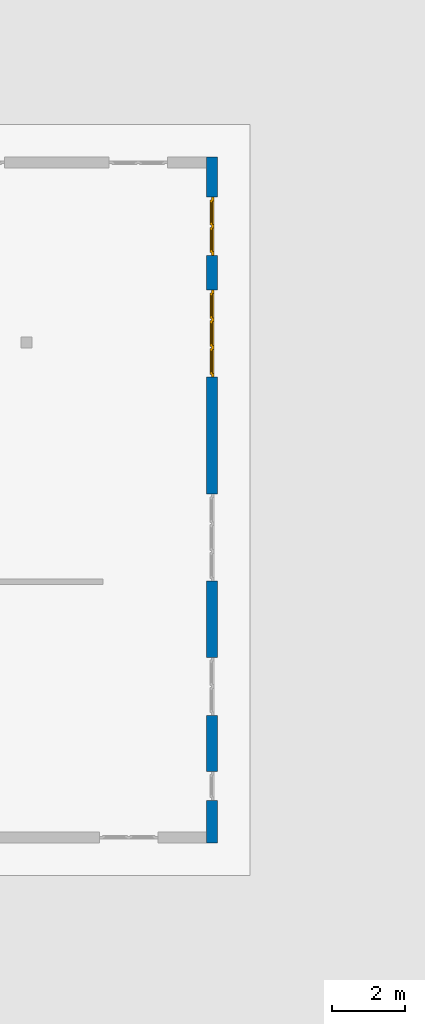
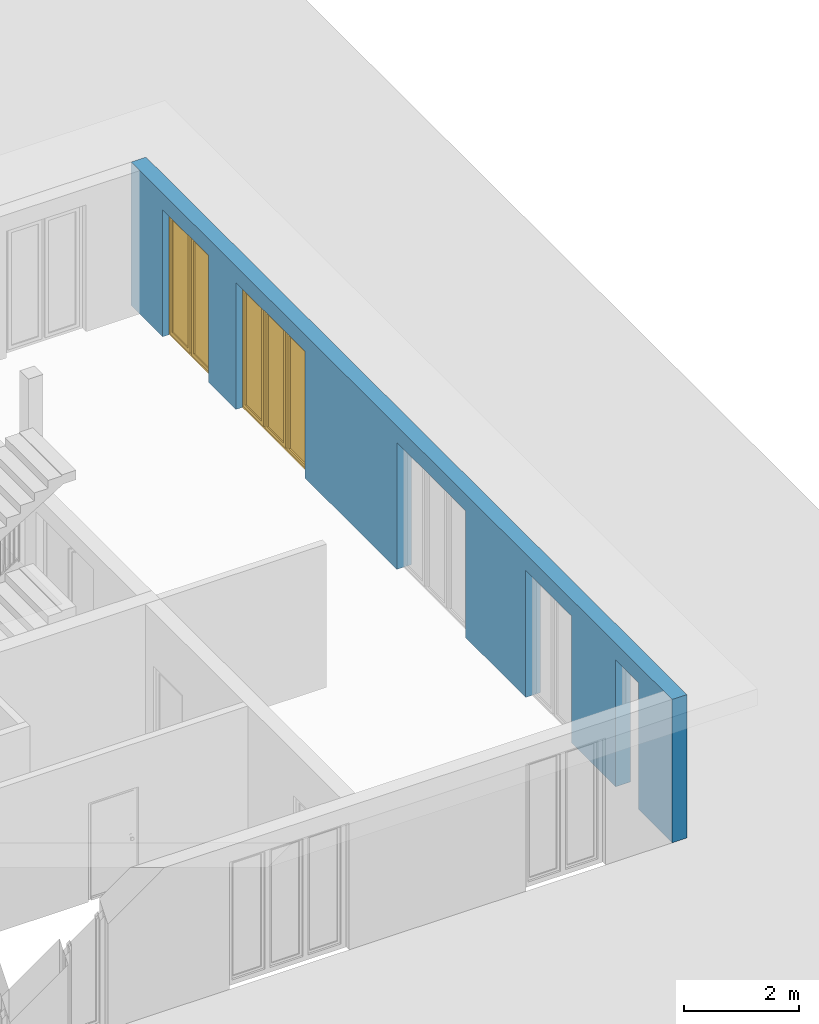
# One storey, part 12 of 23: 2 windows, 1 wall, 5 openings.
"""IFC4 building model written with IfcOpenShell, lengths in metres."""

import ifcopenshell
import ifcopenshell.guid

model = None  # the IFC model being written
_history = None  # IfcOwnerHistory: only IFC2X3 demands one
_inside = {}  # id of a spatial element -> (the spatial element, [elements in it])
_under = {}  # id of a project, library or spatial element -> (it, [spatial elements below it])
_declared = {}  # id of a project -> (the project, [libraries it declares])
_typed = {}  # id of a type object -> (the type object, [elements of that type])
_made_of = {}  # id of a material, layer set ... -> (it, [elements and type objects made of it])


def new_model(schema):
    """Start an empty IFC model of exactly this schema.

    Asked for "IFC4X3", IfcOpenShell would pick the latest addendum, in which some entities
    have other attributes; the version numbers below select the first issue.
    IFC2X3 requires an IfcOwnerHistory on every rooted entity: one is made here for all.
    """
    global model, _history
    if schema == "IFC4X3":
        model = ifcopenshell.file(schema_version=(4, 3, 0, 0))
    else:
        model = ifcopenshell.file(schema=schema)
    _inside.clear()
    _under.clear()
    _declared.clear()
    _typed.clear()
    _made_of.clear()
    _history = None
    if model.schema == "IFC2X3":
        org = make("IfcOrganization", Name="unknown")
        user = make(
            "IfcPersonAndOrganization",
            ThePerson=make("IfcPerson", FamilyName="unknown"),
            TheOrganization=org,
        )
        app = make(
            "IfcApplication",
            ApplicationDeveloper=org,
            Version="unknown",
            ApplicationFullName="unknown",
            ApplicationIdentifier="unknown",
        )
        _history = make(
            "IfcOwnerHistory",
            OwningUser=user,
            OwningApplication=app,
            ChangeAction="ADDED",
            CreationDate=0,
        )
    return model


def make(cls, **values):
    """One entity of the class cls with the attributes given. An attribute that is None is left unset."""
    return model.create_entity(
        cls, **{name: value for name, value in values.items() if value is not None}
    )


def entity(cls, *values):
    """Any entity or typed value of the class cls, its attributes in the order of the schema. None: left unset."""
    e = model.create_entity(cls)
    for i, value in enumerate(values):
        if value is not None:
            e[i] = value
    return e


def rooted(cls, **values):
    """An entity with a GlobalId (a new one), such as an element, a storey or a relation."""
    return make(cls, GlobalId=ifcopenshell.guid.new(), OwnerHistory=_history, **values)


def si_unit(unit_type, name, prefix=None):
    """IfcSIUnit, for example si_unit("LENGTHUNIT", "METRE", prefix="MILLI")."""
    return make("IfcSIUnit", UnitType=unit_type, Prefix=prefix, Name=name)


def converted_unit(unit_type, name, factor, base, dimensions=None, offset=None):
    """IfcConversionBasedUnit, such as the inch: factor (a typed value) times the base unit."""
    return make(
        "IfcConversionBasedUnit"
        if offset is None
        else "IfcConversionBasedUnitWithOffset",
        ConversionOffset=offset,
        Dimensions=None
        if dimensions is None
        else entity("IfcDimensionalExponents", *dimensions),
        UnitType=unit_type,
        Name=name,
        ConversionFactor=make(
            "IfcMeasureWithUnit", ValueComponent=factor, UnitComponent=base
        ),
    )


def derived_unit(unit_type, elements):
    """IfcDerivedUnit: a product of units, each with its exponent."""
    return make(
        "IfcDerivedUnit",
        Elements=[
            make("IfcDerivedUnitElement", Unit=unit, Exponent=power)
            for unit, power in elements
        ],
        UnitType=unit_type,
    )


def assignment(units):
    """IfcUnitAssignment: the units of a project."""
    return None if units is None else make("IfcUnitAssignment", Units=units)


def point(xyz):
    """IfcCartesianPoint."""
    return None if xyz is None else make("IfcCartesianPoint", Coordinates=xyz)


def direction(xyz):
    """IfcDirection."""
    return None if xyz is None else make("IfcDirection", DirectionRatios=xyz)


def frame(location, z_axis=None, x_axis=None):
    """IfcAxis2Placement3D, a coordinate frame: its origin and axes. An axis left out is left unset."""
    return make(
        "IfcAxis2Placement3D",
        Location=point(location),
        Axis=direction(z_axis),
        RefDirection=direction(x_axis),
    )


def origin_with_axes():
    """The frame at (0, 0, 0) with the z axis (0, 0, 1) and the x axis (1, 0, 0) written out."""
    return frame((0.0, 0.0, 0.0), z_axis=(0.0, 0.0, 1.0), x_axis=(1.0, 0.0, 0.0))


def place(relative_to, where):
    """IfcLocalPlacement: puts the frame where relative to a parent placement (None: the world)."""
    return make(
        "IfcLocalPlacement", PlacementRelTo=relative_to, RelativePlacement=where
    )


def context(
    kind, dimensions, precision=None, world=None, true_north=None, identifier=None
):
    """IfcGeometricRepresentationContext, for example the 3D "Model" context."""
    return make(
        "IfcGeometricRepresentationContext",
        ContextIdentifier=identifier,
        ContextType=kind,
        CoordinateSpaceDimension=dimensions,
        Precision=precision,
        WorldCoordinateSystem=world,
        TrueNorth=true_north,
    )


def subcontext(parent, identifier, kind, view, scale=None):
    """IfcGeometricRepresentationSubContext, for example "Body" below "Model"."""
    return make(
        "IfcGeometricRepresentationSubContext",
        ContextIdentifier=identifier,
        ContextType=kind,
        ParentContext=parent,
        TargetScale=scale,
        TargetView=view,
    )


def project(units=None, contexts=None):
    """IfcProject with its units and contexts."""
    return rooted(
        "IfcProject",
        Name="project",
        RepresentationContexts=contexts,
        UnitsInContext=assignment(units),
    )


def spatial(cls, under=None, at=None, **own):
    """A site, building, storey or space (cls), placed at a placement, below another one or the project."""
    s = rooted(cls, ObjectPlacement=at, **own)
    if under is not None:
        _under.setdefault(under.id(), (under, []))[1].append(s)
    return s


def point_list(points):
    """IfcCartesianPointList2D or 3D."""
    cls = (
        "IfcCartesianPointList2D" if len(points[0]) == 2 else "IfcCartesianPointList3D"
    )
    return make(cls, CoordList=points)


def polygons(points, faces, closed=None, point_numbers=None):
    """IfcPolygonalFaceSet: a face is its outer loop, then its inner loops; points numbered from 1."""
    made = []
    for loops in faces:
        if len(loops) == 1:
            made.append(make("IfcIndexedPolygonalFace", CoordIndex=loops[0]))
        else:
            made.append(
                make(
                    "IfcIndexedPolygonalFaceWithVoids",
                    CoordIndex=loops[0],
                    InnerCoordIndices=loops[1:],
                )
            )
    return make(
        "IfcPolygonalFaceSet",
        Coordinates=point_list(points),
        Closed=closed,
        Faces=made,
        PnIndex=point_numbers,
    )


def shape(context_of_items, identifier, shape_type, items):
    """IfcShapeRepresentation: the items that make up one representation, for example the "Body"."""
    return make(
        "IfcShapeRepresentation",
        ContextOfItems=context_of_items,
        RepresentationIdentifier=identifier,
        RepresentationType=shape_type,
        Items=items,
    )


def source(mapping_origin, context_of_items, identifier, shape_type, items):
    """IfcRepresentationMap: a shape defined once, which mapped items show again and again."""
    return make(
        "IfcRepresentationMap",
        MappingOrigin=mapping_origin,
        MappedRepresentation=shape(context_of_items, identifier, shape_type, items),
    )


def transform(
    local_origin,
    x_axis=None,
    y_axis=None,
    z_axis=None,
    scale=None,
    scale2=None,
    scale3=None,
    uniform=True,
):
    """IfcCartesianTransformationOperator3D, or its non-uniform kind. x_axis, y_axis, z_axis: its Axis1, 2, 3."""
    if uniform:
        return make(
            "IfcCartesianTransformationOperator3D",
            Axis1=direction(x_axis),
            Axis2=direction(y_axis),
            LocalOrigin=point(local_origin),
            Scale=scale,
            Axis3=direction(z_axis),
        )
    return make(
        "IfcCartesianTransformationOperator3DnonUniform",
        Axis1=direction(x_axis),
        Axis2=direction(y_axis),
        LocalOrigin=point(local_origin),
        Scale=scale,
        Axis3=direction(z_axis),
        Scale2=scale2,
        Scale3=scale3,
    )


def mapped(mapping_source, mapping_target):
    """IfcMappedItem: shows the shape of a source again, moved by a transform."""
    return make(
        "IfcMappedItem", MappingSource=mapping_source, MappingTarget=mapping_target
    )


def material(Name=None, Category=None):
    """IfcMaterial."""
    return make("IfcMaterial", Name=Name, Category=Category)


def made_of(thing, what):
    """Note that an element or type object is made of a material, layer set ...; save() writes the relation."""
    if what is not None:
        _made_of.setdefault(what.id(), (what, []))[1].append(thing)
    return thing


def type_object(cls, material=None, **own):
    """A type object (cls), such as IfcWallType, which elements share."""
    return made_of(rooted(cls, **own), material)


def element(
    cls,
    number,
    at=None,
    inside=None,
    cuts=None,
    type_object=None,
    material=None,
    context=None,
    identifier="Body",
    shape_type=None,
    held_by="IfcProductDefinitionShape",
    body=None,
    shapes=None,
    **own,
):
    """One element of the class cls, such as IfcWall. Its Tag is "e" and its number.

    at: its placement. inside: the storey or other place that contains it. cuts: it is an
    opening in that element (IfcRelVoidsElement). A single representation is given by context,
    identifier, shape_type and body (its items); several are given by shapes. held_by: the class
    of the entity that holds the representations. save() writes the other relations.
    """
    e = rooted(cls, Tag="e%d" % number, ObjectPlacement=at, **own)
    if body is not None:
        shapes = [shape(context, identifier, shape_type, body)]
    if shapes is not None:
        e.Representation = make(held_by, Representations=shapes)
    if inside is not None:
        _inside.setdefault(inside.id(), (inside, []))[1].append(e)
    if cuts is not None:
        rooted(
            "IfcRelVoidsElement", RelatingBuildingElement=cuts, RelatedOpeningElement=e
        )
    if type_object is not None:
        _typed.setdefault(type_object.id(), (type_object, []))[1].append(e)
    return made_of(e, material)


def fill(opening, filler):
    """IfcRelFillsElement: the door or window that sits in an opening."""
    return rooted(
        "IfcRelFillsElement",
        RelatingOpeningElement=opening,
        RelatedBuildingElement=filler,
    )


def aggregate(whole, parts):
    """IfcRelAggregates: a whole, such as a stair, and the parts it consists of."""
    return rooted("IfcRelAggregates", RelatingObject=whole, RelatedObjects=parts)


def save(model, path):
    """Write the relations noted so far, then the file.

    IfcRelAggregates (storeys below a building ...), IfcRelContainedInSpatialStructure (elements
    in a storey), IfcRelDefinesByType, IfcRelAssociatesMaterial and IfcRelDeclares: one each for
    every whole, place, type object, material and project.
    """
    for whole, parts in _under.values():
        aggregate(whole, parts)
    for where, things in _inside.values():
        rooted(
            "IfcRelContainedInSpatialStructure",
            RelatedElements=things,
            RelatingStructure=where,
        )
    for kind, things in _typed.values():
        rooted("IfcRelDefinesByType", RelatedObjects=things, RelatingType=kind)
    for what, things in _made_of.values():
        rooted("IfcRelAssociatesMaterial", RelatedObjects=things, RelatingMaterial=what)
    for by, libraries in _declared.values():
        rooted("IfcRelDeclares", RelatingContext=by, RelatedDefinitions=libraries)
    model.write(path)


model = new_model("IFC4")

# Units and contexts
model_context = context("Model", 3, precision=1e-05, world=origin_with_axes(), true_north=direction((0.0, 1.0)))
body_context = subcontext(model_context, "Body", "Model", "MODEL_VIEW")
ifc_project = project(units=[si_unit("LENGTHUNIT", "METRE"), si_unit("AREAUNIT", "SQUARE_METRE"), si_unit("VOLUMEUNIT", "CUBIC_METRE"), converted_unit("PLANEANGLEUNIT", "DEGREE", entity("IfcPlaneAngleMeasure", 0.0174532925199), si_unit("PLANEANGLEUNIT", "RADIAN"), dimensions=[0, 0, 0, 0, 0, 0, 0]), converted_unit("TIMEUNIT", "Year", entity("IfcTimeMeasure", 31556926.0), si_unit("TIMEUNIT", "SECOND"), dimensions=[0, 0, 1, 0, 0, 0, 0]), si_unit("MASSUNIT", "GRAM", prefix="KILO"), si_unit("THERMODYNAMICTEMPERATUREUNIT", "DEGREE_CELSIUS"), si_unit("LUMINOUSINTENSITYUNIT", "LUMEN"), si_unit("ENERGYUNIT", "JOULE", prefix="MEGA"), derived_unit("THERMALCONDUCTANCEUNIT", [(si_unit("POWERUNIT", "WATT"), 1), (si_unit("LENGTHUNIT", "METRE"), -1), (si_unit("THERMODYNAMICTEMPERATUREUNIT", "KELVIN"), -1)]), derived_unit("SPECIFICHEATCAPACITYUNIT", [(si_unit("ENERGYUNIT", "JOULE"), 1), (si_unit("MASSUNIT", "GRAM", prefix="KILO"), -1), (si_unit("THERMODYNAMICTEMPERATUREUNIT", "KELVIN"), -1)]), derived_unit("MASSDENSITYUNIT", [(si_unit("MASSUNIT", "GRAM", prefix="KILO"), 1), (si_unit("VOLUMEUNIT", "CUBIC_METRE"), -1)])], contexts=[model_context])

# Site, building, storey
site_placement = place(None, origin_with_axes())
site = spatial("IfcSite", under=ifc_project, at=site_placement, CompositionType="ELEMENT")
building_placement = place(site_placement, origin_with_axes())
building = spatial("IfcBuilding", under=site, at=building_placement, CompositionType="ELEMENT")
storey_placement = place(building_placement, origin_with_axes())
storey = spatial("IfcBuildingStorey", under=building, at=storey_placement, Name="0. Geschoss", CompositionType="ELEMENT", Elevation=0.0)

# Wall, openings, windows
ifc_material = material()
wall_type = type_object("IfcWallType", Name="300", PredefinedType="NOTDEFINED")
wall_placement = place(storey_placement, frame((9.3378006196, -9.92881223104, 0.0), z_axis=(0.0, 0.0, 1.0), x_axis=(0.0, 1.0, 0.0)))
wall = element("IfcWall", 1, at=wall_placement, inside=storey, type_object=wall_type, material=ifc_material, Name="Wand-001", PredefinedType="NOTDEFINED", context=body_context, shape_type="Tessellation", body=[
    polygons([(1.16441876325, 0.1, 2.7), (1.96441876325, 0.1, 2.7), (1.96441876325, 0.0, 2.7), (1.16441876325, 0.0, 2.7), (1.16441876325, 0.3, 2.7), (1.96441876325, 0.3, 2.7), (1.96441876325, 0.1, 0.0), (1.96441876325, 0.0, 0.0), (18.85, 0.0, 3.05), (0.0, 0.0, 3.05), (0.0, 0.0, 0.0), (1.16441876325, 0.0, 0.0), (3.5, 0.0, 0.0), (3.5, 0.0, 2.7), (5.1, 0.0, 2.7), (5.1, 0.0, 0.0), (7.1921181063, 0.0, 0.0), (7.1921181063, 0.0, 2.7), (9.5921181063, 0.0, 2.7), (9.5921181063, 0.0, 0.0), (12.8, 0.0, 0.0), (12.8, 0.0, 2.7), (15.2, 0.0, 2.7), (15.2, 0.0, 0.0), (16.15, 0.0, 0.0), (16.15, 0.0, 2.7), (17.75, 0.0, 2.7), (17.75, 0.0, 0.0), (18.85, 0.0, 0.0), (1.16441876325, 0.1, 0.0), (1.16441876325, 0.3, 0.0), (0.0, 0.3, 0.0), (0.0, 0.3, 3.05), (18.85, 0.3, 3.05), (18.85, 0.3, 0.0), (17.75, 0.3, 0.0), (17.75, 0.3, 2.7), (16.15, 0.3, 2.7), (16.15, 0.3, 0.0), (15.2, 0.3, 0.0), (15.2, 0.3, 2.7), (12.8, 0.3, 2.7), (12.8, 0.3, 0.0), (9.5921181063, 0.3, 0.0), (9.5921181063, 0.3, 2.7), (7.1921181063, 0.3, 2.7), (7.1921181063, 0.3, 0.0), (5.1, 0.3, 0.0), (5.1, 0.3, 2.7), (3.5, 0.3, 2.7), (3.5, 0.3, 0.0), (1.96441876325, 0.3, 0.0), (3.5, 0.1, 0.0), (3.5, 0.1, 2.7), (5.1, 0.1, 2.7), (5.1, 0.1, 0.0), (7.1921181063, 0.1, 0.0), (7.1921181063, 0.1, 2.7), (9.5921181063, 0.1, 2.7), (9.5921181063, 0.1, 0.0), (12.8, 0.1, 0.0), (12.8, 0.1, 2.7), (15.2, 0.1, 2.7), (15.2, 0.1, 0.0), (16.15, 0.1, 0.0), (16.15, 0.1, 2.7), (17.75, 0.1, 2.7), (17.75, 0.1, 0.0)], [[[1, 2, 3, 4]], [[2, 1, 5, 6]], [[2, 7, 8, 3]], [[9, 10, 11, 12, 4, 3, 8, 13, 14, 15, 16, 17, 18, 19, 20, 21, 22, 23, 24, 25, 26, 27, 28, 29]], [[30, 1, 4, 12]], [[1, 30, 31, 5]], [[5, 31, 32, 33, 34, 35, 36, 37, 38, 39, 40, 41, 42, 43, 44, 45, 46, 47, 48, 49, 50, 51, 52, 6]], [[7, 2, 6, 52]], [[7, 52, 51, 53, 13, 8]], [[9, 34, 33, 10]], [[33, 32, 11, 10]], [[31, 30, 12, 11, 32]], [[14, 13, 53, 54]], [[15, 14, 54, 55]], [[16, 15, 55, 56]], [[56, 48, 47, 57, 17, 16]], [[57, 58, 18, 17]], [[58, 59, 19, 18]], [[59, 60, 20, 19]], [[60, 44, 43, 61, 21, 20]], [[22, 21, 61, 62]], [[23, 22, 62, 63]], [[24, 23, 63, 64]], [[64, 40, 39, 65, 25, 24]], [[65, 66, 26, 25]], [[66, 67, 27, 26]], [[67, 68, 28, 27]], [[36, 35, 29, 28, 68]], [[9, 29, 35, 34]], [[68, 67, 37, 36]], [[67, 66, 38, 37]], [[66, 65, 39, 38]], [[41, 40, 64, 63]], [[42, 41, 63, 62]], [[43, 42, 62, 61]], [[60, 59, 45, 44]], [[59, 58, 46, 45]], [[58, 57, 47, 46]], [[49, 48, 56, 55]], [[50, 49, 55, 54]], [[51, 50, 54, 53]]], closed=True),
])
opening_1_placement = place(wall_placement, frame((16.95, 0.0, 0.0), z_axis=(0.0, 0.0, 1.0), x_axis=(1.0, 0.0, 0.0)))
opening_1 = element("IfcOpeningElement", 2, at=opening_1_placement, cuts=wall, Name="Fenster-001", context=body_context, identifier="Reference", shape_type="Tessellation", body=[
    polygons([(0.8, 0.1, 0.0), (0.8, 0.1, 2.7), (0.8, -0.000999999999999, 2.7), (0.8, -0.000999999999999, 0.0), (0.8, 0.301, 0.0), (0.8, 0.301, 2.7), (-0.8, 0.1, 2.7), (-0.8, -0.000999999999999, 2.7), (-0.8, 0.301, 2.7), (-0.8, -0.000999999999999, 0.0), (-0.8, 0.1, 0.0), (-0.8, 0.301, 0.0)], [[[1, 2, 3, 4]], [[2, 1, 5, 6]], [[7, 8, 3, 2, 6, 9]], [[8, 10, 4, 3]], [[1, 4, 10, 11, 12, 5]], [[6, 5, 12, 9]], [[7, 11, 10, 8]], [[11, 7, 9, 12]]], closed=True),
])
opening_2_placement = place(wall_placement, frame((14.0, 0.0, 0.0), z_axis=(0.0, 0.0, 1.0), x_axis=(1.0, 0.0, 0.0)))
opening_2 = element("IfcOpeningElement", 3, at=opening_2_placement, cuts=wall, Name="Fenster-002", context=body_context, identifier="Reference", shape_type="Tessellation", body=[
    polygons([(1.2, 0.1, 0.0), (1.2, 0.1, 2.7), (1.2, -0.000999999999999, 2.7), (1.2, -0.000999999999999, 0.0), (1.2, 0.301, 0.0), (1.2, 0.301, 2.7), (-1.2, 0.1, 2.7), (-1.2, -0.000999999999999, 2.7), (-1.2, 0.301, 2.7), (-1.2, -0.000999999999999, 0.0), (-1.2, 0.1, 0.0), (-1.2, 0.301, 0.0)], [[[1, 2, 3, 4]], [[2, 1, 5, 6]], [[7, 8, 3, 2, 6, 9]], [[8, 10, 4, 3]], [[1, 4, 10, 11, 12, 5]], [[6, 5, 12, 9]], [[7, 11, 10, 8]], [[11, 7, 9, 12]]], closed=True),
])
opening_3_placement = place(wall_placement, frame((8.3921181063, 0.0, 0.0), z_axis=(0.0, 0.0, 1.0), x_axis=(1.0, 0.0, 0.0)))
element("IfcOpeningElement", 4, at=opening_3_placement, cuts=wall, Name="Fenster-002", context=body_context, identifier="Reference", shape_type="Tessellation", body=[
    polygons([(1.2, 0.1, 0.0), (1.2, 0.1, 2.7), (1.2, -0.000999999999999, 2.7), (1.2, -0.000999999999999, 0.0), (1.2, 0.301, 0.0), (1.2, 0.301, 2.7), (-1.2, 0.1, 2.7), (-1.2, -0.000999999999999, 2.7), (-1.2, 0.301, 2.7), (-1.2, -0.000999999999999, 0.0), (-1.2, 0.1, 0.0), (-1.2, 0.301, 0.0)], [[[1, 2, 3, 4]], [[2, 1, 5, 6]], [[7, 8, 3, 2, 6, 9]], [[8, 10, 4, 3]], [[1, 4, 10, 11, 12, 5]], [[6, 5, 12, 9]], [[7, 11, 10, 8]], [[11, 7, 9, 12]]], closed=True),
])
opening_4_placement = place(wall_placement, frame((4.3, 0.0, 0.0), z_axis=(0.0, 0.0, 1.0), x_axis=(1.0, 0.0, 0.0)))
element("IfcOpeningElement", 5, at=opening_4_placement, cuts=wall, Name="Fenster-001", context=body_context, identifier="Reference", shape_type="Tessellation", body=[
    polygons([(0.8, 0.1, 0.0), (0.8, 0.1, 2.7), (0.8, -0.000999999999999, 2.7), (0.8, -0.000999999999999, 0.0), (0.8, 0.301, 0.0), (0.8, 0.301, 2.7), (-0.8, 0.1, 2.7), (-0.8, -0.000999999999999, 2.7), (-0.8, 0.301, 2.7), (-0.8, -0.000999999999999, 0.0), (-0.8, 0.1, 0.0), (-0.8, 0.301, 0.0)], [[[1, 2, 3, 4]], [[2, 1, 5, 6]], [[7, 8, 3, 2, 6, 9]], [[8, 10, 4, 3]], [[1, 4, 10, 11, 12, 5]], [[6, 5, 12, 9]], [[7, 11, 10, 8]], [[11, 7, 9, 12]]], closed=True),
])
opening_5_placement = place(wall_placement, frame((1.56441876325, 0.0, 0.0), z_axis=(0.0, 0.0, 1.0), x_axis=(1.0, 0.0, 0.0)))
element("IfcOpeningElement", 6, at=opening_5_placement, cuts=wall, Name="Fenster-003", context=body_context, identifier="Reference", shape_type="Tessellation", body=[
    polygons([(0.4, 0.1, 0.0), (0.4, 0.1, 2.7), (0.4, -0.000999999999999, 2.7), (0.4, -0.000999999999999, 0.0), (0.4, 0.301, 0.0), (0.4, 0.301, 2.7), (-0.4, 0.1, 2.7), (-0.4, -0.000999999999999, 2.7), (-0.4, 0.301, 2.7), (-0.4, -0.000999999999999, 0.0), (-0.4, 0.1, 0.0), (-0.4, 0.301, 0.0)], [[[1, 2, 3, 4]], [[2, 1, 5, 6]], [[7, 8, 3, 2, 6, 9]], [[8, 10, 4, 3]], [[1, 4, 10, 11, 12, 5]], [[6, 5, 12, 9]], [[7, 11, 10, 8]], [[11, 7, 9, 12]]], closed=True),
])
window_type_1 = type_object("IfcWindowType", Name="2-1+1 26", PartitioningType="DOUBLE_PANEL_VERTICAL", PredefinedType="WINDOW")
shared_shape_1 = source(origin_with_axes(), body_context, "Body", "Tessellation", [
    polygons([(-0.8, -0.07, 0.0), (-0.8, 0.0, 0.0), (-0.7, 0.0, 0.1), (-0.7, -0.07, 0.1), (-0.8, -0.07, 2.7), (-0.8, 0.0, 2.7), (-0.7, 0.0, 2.6), (-0.7, -0.07, 2.6)], [[[1, 2, 3, 4]], [[5, 6, 2, 1]], [[2, 6, 7, 3]], [[4, 3, 7, 8]], [[1, 4, 8, 5]], [[8, 7, 6, 5]]], closed=True),
    polygons([(0.8, -0.07, 0.0), (0.8, 0.0, 0.0), (0.8, 0.0, 2.7), (0.8, -0.07, 2.7), (0.7, -0.07, 0.1), (0.7, 0.0, 0.1), (0.7, 0.0, 2.6), (0.7, -0.07, 2.6)], [[[1, 2, 3, 4]], [[5, 6, 2, 1]], [[2, 6, 7, 3]], [[4, 3, 7, 8]], [[1, 4, 8, 5]], [[8, 7, 6, 5]]], closed=True),
    polygons([(-0.8, -0.07, 0.0), (-0.8, 0.0, 0.0), (0.8, 0.0, 0.0), (0.8, -0.07, 0.0), (-0.7, -0.07, 0.1), (-0.7, 0.0, 0.1), (-0.05, 0.0, 0.1), (0.05, 0.0, 0.1), (0.7, 0.0, 0.1), (0.7, -0.07, 0.1), (0.05, -0.07, 0.1), (-0.05, -0.07, 0.1)], [[[1, 2, 3, 4]], [[5, 6, 2, 1]], [[2, 6, 7, 8, 9, 3]], [[4, 3, 9, 10]], [[1, 4, 10, 11, 12, 5]], [[12, 7, 6, 5]], [[11, 8, 7, 12]], [[10, 9, 8, 11]]], closed=True),
    polygons([(-0.8, -0.07, 2.7), (-0.8, 0.0, 2.7), (-0.7, 0.0, 2.6), (-0.7, -0.07, 2.6), (0.8, -0.07, 2.7), (0.8, 0.0, 2.7), (0.7, 0.0, 2.6), (0.05, 0.0, 2.6), (-0.05, 0.0, 2.6), (-0.05, -0.07, 2.6), (0.05, -0.07, 2.6), (0.7, -0.07, 2.6)], [[[1, 2, 3, 4]], [[5, 6, 2, 1]], [[2, 6, 7, 8, 9, 3]], [[4, 3, 9, 10]], [[1, 4, 10, 11, 12, 5]], [[12, 7, 6, 5]], [[11, 8, 7, 12]], [[10, 9, 8, 11]]], closed=True),
    polygons([(-0.05, -0.07, 0.1), (-0.05, 0.0, 0.1), (0.05, 0.0, 0.1), (0.05, -0.07, 0.1), (-0.05, -0.07, 2.6), (-0.05, 0.0, 2.6), (0.05, 0.0, 2.6), (0.05, -0.07, 2.6)], [[[1, 2, 3, 4]], [[5, 6, 2, 1]], [[2, 6, 7, 3]], [[4, 3, 7, 8]], [[1, 4, 8, 5]], [[8, 7, 6, 5]]], closed=True),
    polygons([(-0.72, 0.0, 0.08), (-0.72, 0.03, 0.08), (-0.65, 0.03, 0.15), (-0.65, 0.0, 0.15), (-0.72, 0.0, 2.62), (-0.72, 0.03, 2.62), (-0.65, 0.03, 2.55), (-0.65, 0.0, 2.55)], [[[1, 2, 3, 4]], [[5, 6, 2, 1]], [[2, 6, 7, 3]], [[4, 3, 7, 8]], [[1, 4, 8, 5]], [[8, 7, 6, 5]]], closed=True),
    polygons([(-0.03, 0.0, 0.08), (-0.1, 0.0, 0.15), (-0.1, 0.03, 0.15), (-0.03, 0.03, 0.08), (-0.03, 0.0, 2.62), (-0.1, 0.0, 2.55), (-0.1, 0.03, 2.55), (-0.03, 0.03, 2.62)], [[[1, 2, 3, 4]], [[1, 5, 6, 2]], [[2, 6, 7, 3]], [[4, 3, 7, 8]], [[5, 1, 4, 8]], [[6, 5, 8, 7]]], closed=True),
    polygons([(-0.72, 0.0, 0.08), (-0.72, 0.03, 0.08), (-0.03, 0.03, 0.08), (-0.03, 0.0, 0.08), (-0.65, 0.0, 0.15), (-0.65, 0.03, 0.15), (-0.1, 0.03, 0.15), (-0.1, 0.0, 0.15)], [[[1, 2, 3, 4]], [[5, 6, 2, 1]], [[2, 6, 7, 3]], [[4, 3, 7, 8]], [[1, 4, 8, 5]], [[8, 7, 6, 5]]], closed=True),
    polygons([(-0.72, 0.0, 2.62), (-0.03, 0.0, 2.62), (-0.03, 0.03, 2.62), (-0.72, 0.03, 2.62), (-0.65, 0.0, 2.55), (-0.1, 0.0, 2.55), (-0.1, 0.03, 2.55), (-0.65, 0.03, 2.55)], [[[1, 2, 3, 4]], [[1, 5, 6, 2]], [[2, 6, 7, 3]], [[4, 3, 7, 8]], [[5, 1, 4, 8]], [[6, 5, 8, 7]]], closed=True),
    polygons([(-0.7, -0.03, 0.1), (-0.7, 0.0, 0.1), (-0.65, 0.0, 0.15), (-0.65, -0.03, 0.15), (-0.7, -0.03, 2.6), (-0.7, 0.0, 2.6), (-0.65, 0.0, 2.55), (-0.65, -0.03, 2.55)], [[[1, 2, 3, 4]], [[5, 6, 2, 1]], [[2, 6, 7, 3]], [[4, 3, 7, 8]], [[1, 4, 8, 5]], [[8, 7, 6, 5]]], closed=True),
    polygons([(-0.05, -0.03, 0.1), (-0.1, -0.03, 0.15), (-0.1, 0.0, 0.15), (-0.05, 0.0, 0.1), (-0.05, -0.03, 2.6), (-0.1, -0.03, 2.55), (-0.1, 0.0, 2.55), (-0.05, 0.0, 2.6)], [[[1, 2, 3, 4]], [[1, 5, 6, 2]], [[2, 6, 7, 3]], [[4, 3, 7, 8]], [[5, 1, 4, 8]], [[6, 5, 8, 7]]], closed=True),
    polygons([(-0.7, -0.03, 0.1), (-0.7, 0.0, 0.1), (-0.05, 0.0, 0.1), (-0.05, -0.03, 0.1), (-0.65, -0.03, 0.15), (-0.65, 0.0, 0.15), (-0.1, 0.0, 0.15), (-0.1, -0.03, 0.15)], [[[1, 2, 3, 4]], [[5, 6, 2, 1]], [[2, 6, 7, 3]], [[4, 3, 7, 8]], [[1, 4, 8, 5]], [[8, 7, 6, 5]]], closed=True),
    polygons([(-0.7, -0.03, 2.6), (-0.05, -0.03, 2.6), (-0.05, 0.0, 2.6), (-0.7, 0.0, 2.6), (-0.65, -0.03, 2.55), (-0.1, -0.03, 2.55), (-0.1, 0.0, 2.55), (-0.65, 0.0, 2.55)], [[[1, 2, 3, 4]], [[1, 5, 6, 2]], [[2, 6, 7, 3]], [[4, 3, 7, 8]], [[5, 1, 4, 8]], [[6, 5, 8, 7]]], closed=True),
    polygons([(-0.65, -0.005, 0.15), (-0.65, 0.005, 0.15), (-0.1, 0.005, 0.15), (-0.1, -0.005, 0.15), (-0.65, -0.005, 2.55), (-0.65, 0.005, 2.55), (-0.1, 0.005, 2.55), (-0.1, -0.005, 2.55)], [[[1, 2, 3, 4]], [[5, 6, 2, 1]], [[2, 6, 7, 3]], [[4, 3, 7, 8]], [[1, 4, 8, 5]], [[8, 7, 6, 5]]], closed=True),
    polygons([(0.03, 0.0, 0.08), (0.03, 0.03, 0.08), (0.1, 0.03, 0.15), (0.1, 0.0, 0.15), (0.03, 0.0, 2.62), (0.03, 0.03, 2.62), (0.1, 0.03, 2.55), (0.1, 0.0, 2.55)], [[[1, 2, 3, 4]], [[5, 6, 2, 1]], [[2, 6, 7, 3]], [[4, 3, 7, 8]], [[1, 4, 8, 5]], [[8, 7, 6, 5]]], closed=True),
    polygons([(0.72, 0.0, 0.08), (0.65, 0.0, 0.15), (0.65, 0.03, 0.15), (0.72, 0.03, 0.08), (0.72, 0.0, 2.62), (0.65, 0.0, 2.55), (0.65, 0.03, 2.55), (0.72, 0.03, 2.62)], [[[1, 2, 3, 4]], [[1, 5, 6, 2]], [[2, 6, 7, 3]], [[4, 3, 7, 8]], [[5, 1, 4, 8]], [[6, 5, 8, 7]]], closed=True),
    polygons([(0.03, 0.0, 0.08), (0.03, 0.03, 0.08), (0.72, 0.03, 0.08), (0.72, 0.0, 0.08), (0.1, 0.0, 0.15), (0.1, 0.03, 0.15), (0.65, 0.03, 0.15), (0.65, 0.0, 0.15)], [[[1, 2, 3, 4]], [[5, 6, 2, 1]], [[2, 6, 7, 3]], [[4, 3, 7, 8]], [[1, 4, 8, 5]], [[8, 7, 6, 5]]], closed=True),
    polygons([(0.03, 0.0, 2.62), (0.72, 0.0, 2.62), (0.72, 0.03, 2.62), (0.03, 0.03, 2.62), (0.1, 0.0, 2.55), (0.65, 0.0, 2.55), (0.65, 0.03, 2.55), (0.1, 0.03, 2.55)], [[[1, 2, 3, 4]], [[1, 5, 6, 2]], [[2, 6, 7, 3]], [[4, 3, 7, 8]], [[5, 1, 4, 8]], [[6, 5, 8, 7]]], closed=True),
    polygons([(0.05, -0.03, 0.1), (0.05, 0.0, 0.1), (0.1, 0.0, 0.15), (0.1, -0.03, 0.15), (0.05, -0.03, 2.6), (0.05, 0.0, 2.6), (0.1, 0.0, 2.55), (0.1, -0.03, 2.55)], [[[1, 2, 3, 4]], [[5, 6, 2, 1]], [[2, 6, 7, 3]], [[4, 3, 7, 8]], [[1, 4, 8, 5]], [[8, 7, 6, 5]]], closed=True),
    polygons([(0.7, -0.03, 0.1), (0.65, -0.03, 0.15), (0.65, 0.0, 0.15), (0.7, 0.0, 0.1), (0.7, -0.03, 2.6), (0.65, -0.03, 2.55), (0.65, 0.0, 2.55), (0.7, 0.0, 2.6)], [[[1, 2, 3, 4]], [[1, 5, 6, 2]], [[2, 6, 7, 3]], [[4, 3, 7, 8]], [[5, 1, 4, 8]], [[6, 5, 8, 7]]], closed=True),
    polygons([(0.05, -0.03, 0.1), (0.05, 0.0, 0.1), (0.7, 0.0, 0.1), (0.7, -0.03, 0.1), (0.1, -0.03, 0.15), (0.1, 0.0, 0.15), (0.65, 0.0, 0.15), (0.65, -0.03, 0.15)], [[[1, 2, 3, 4]], [[5, 6, 2, 1]], [[2, 6, 7, 3]], [[4, 3, 7, 8]], [[1, 4, 8, 5]], [[8, 7, 6, 5]]], closed=True),
    polygons([(0.05, -0.03, 2.6), (0.7, -0.03, 2.6), (0.7, 0.0, 2.6), (0.05, 0.0, 2.6), (0.1, -0.03, 2.55), (0.65, -0.03, 2.55), (0.65, 0.0, 2.55), (0.1, 0.0, 2.55)], [[[1, 2, 3, 4]], [[1, 5, 6, 2]], [[2, 6, 7, 3]], [[4, 3, 7, 8]], [[5, 1, 4, 8]], [[6, 5, 8, 7]]], closed=True),
    polygons([(0.1, -0.005, 0.15), (0.1, 0.005, 0.15), (0.65, 0.005, 0.15), (0.65, -0.005, 0.15), (0.1, -0.005, 2.55), (0.1, 0.005, 2.55), (0.65, 0.005, 2.55), (0.65, -0.005, 2.55)], [[[1, 2, 3, 4]], [[5, 6, 2, 1]], [[2, 6, 7, 3]], [[4, 3, 7, 8]], [[1, 4, 8, 5]], [[8, 7, 6, 5]]], closed=True),
])
window_1_placement = place(opening_1_placement, frame((-0.8, 0.0, 0.0), z_axis=(0.0, 0.0, 1.0), x_axis=(1.0, 0.0, 0.0)))
window_1 = element("IfcWindow", 7, at=window_1_placement, inside=storey, type_object=window_type_1, Name="Fenster-001", OverallHeight=2.7, OverallWidth=1.6, PredefinedType="WINDOW", context=body_context, shape_type="MappedRepresentation", body=[
    mapped(shared_shape_1, transform((0.8, 0.17, 0.0))),
])
fill(opening_1, window_1)
window_type_2 = type_object("IfcWindowType", Name="3-1+1+1 26", PartitioningType="TRIPLE_PANEL_VERTICAL", PredefinedType="WINDOW")
shared_shape_2 = source(origin_with_axes(), body_context, "Body", "Tessellation", [
    polygons([(1.2, -0.07, 0.0), (1.1, -0.07, 0.1), (1.1, 0.0, 0.1), (1.2, 0.0, 0.0), (1.2, -0.07, 2.7), (1.1, -0.07, 2.6), (1.1, 0.0, 2.6), (1.2, 0.0, 2.7)], [[[1, 2, 3, 4]], [[1, 5, 6, 2]], [[2, 6, 7, 3]], [[4, 3, 7, 8]], [[5, 1, 4, 8]], [[6, 5, 8, 7]]], closed=True),
    polygons([(-1.2, -0.07, 0.0), (-1.2, -0.07, 2.7), (-1.2, 0.0, 2.7), (-1.2, 0.0, 0.0), (-1.1, -0.07, 0.1), (-1.1, -0.07, 2.6), (-1.1, 0.0, 2.6), (-1.1, 0.0, 0.1)], [[[1, 2, 3, 4]], [[1, 5, 6, 2]], [[2, 6, 7, 3]], [[4, 3, 7, 8]], [[5, 1, 4, 8]], [[6, 5, 8, 7]]], closed=True),
    polygons([(1.2, -0.07, 0.0), (-1.2, -0.07, 0.0), (-1.2, 0.0, 0.0), (1.2, 0.0, 0.0), (1.1, -0.07, 0.1), (0.433333333333, -0.07, 0.1), (0.333333333333, -0.07, 0.1), (-0.333333333333, -0.07, 0.1), (-0.433333333333, -0.07, 0.1), (-1.1, -0.07, 0.1), (-1.1, 0.0, 0.1), (-0.433333333333, 0.0, 0.1), (-0.333333333333, 0.0, 0.1), (0.333333333333, 0.0, 0.1), (0.433333333333, 0.0, 0.1), (1.1, 0.0, 0.1)], [[[1, 2, 3, 4]], [[1, 5, 6, 7, 8, 9, 10, 2]], [[2, 10, 11, 3]], [[4, 3, 11, 12, 13, 14, 15, 16]], [[5, 1, 4, 16]], [[6, 5, 16, 15]], [[7, 6, 15, 14]], [[8, 7, 14, 13]], [[9, 8, 13, 12]], [[10, 9, 12, 11]]], closed=True),
    polygons([(1.2, -0.07, 2.7), (1.1, -0.07, 2.6), (1.1, 0.0, 2.6), (1.2, 0.0, 2.7), (-1.2, -0.07, 2.7), (-1.1, -0.07, 2.6), (-0.433333333333, -0.07, 2.6), (-0.333333333333, -0.07, 2.6), (0.333333333333, -0.07, 2.6), (0.433333333333, -0.07, 2.6), (0.433333333333, 0.0, 2.6), (0.333333333333, 0.0, 2.6), (-0.333333333333, 0.0, 2.6), (-0.433333333333, 0.0, 2.6), (-1.1, 0.0, 2.6), (-1.2, 0.0, 2.7)], [[[1, 2, 3, 4]], [[1, 5, 6, 7, 8, 9, 10, 2]], [[2, 10, 11, 3]], [[4, 3, 11, 12, 13, 14, 15, 16]], [[5, 1, 4, 16]], [[6, 5, 16, 15]], [[7, 6, 15, 14]], [[8, 7, 14, 13]], [[9, 8, 13, 12]], [[10, 9, 12, 11]]], closed=True),
    polygons([(-0.333333333333, -0.07, 0.1), (-0.433333333333, -0.07, 0.1), (-0.433333333333, 0.0, 0.1), (-0.333333333333, 0.0, 0.1), (-0.333333333333, -0.07, 2.6), (-0.433333333333, -0.07, 2.6), (-0.433333333333, 0.0, 2.6), (-0.333333333333, 0.0, 2.6)], [[[1, 2, 3, 4]], [[1, 5, 6, 2]], [[2, 6, 7, 3]], [[4, 3, 7, 8]], [[5, 1, 4, 8]], [[6, 5, 8, 7]]], closed=True),
    polygons([(0.433333333333, -0.07, 0.1), (0.333333333333, -0.07, 0.1), (0.333333333333, 0.0, 0.1), (0.433333333333, 0.0, 0.1), (0.433333333333, -0.07, 2.6), (0.333333333333, -0.07, 2.6), (0.333333333333, 0.0, 2.6), (0.433333333333, 0.0, 2.6)], [[[1, 2, 3, 4]], [[1, 5, 6, 2]], [[2, 6, 7, 3]], [[4, 3, 7, 8]], [[5, 1, 4, 8]], [[6, 5, 8, 7]]], closed=True),
    polygons([(1.12, 0.0, 0.08), (1.05, 0.0, 0.15), (1.05, 0.03, 0.15), (1.12, 0.03, 0.08), (1.12, 0.0, 2.62), (1.05, 0.0, 2.55), (1.05, 0.03, 2.55), (1.12, 0.03, 2.62)], [[[1, 2, 3, 4]], [[1, 5, 6, 2]], [[2, 6, 7, 3]], [[4, 3, 7, 8]], [[5, 1, 4, 8]], [[6, 5, 8, 7]]], closed=True),
    polygons([(0.413333333333, 0.0, 0.08), (0.413333333333, 0.03, 0.08), (0.483333333333, 0.03, 0.15), (0.483333333333, 0.0, 0.15), (0.413333333333, 0.0, 2.62), (0.413333333333, 0.03, 2.62), (0.483333333333, 0.03, 2.55), (0.483333333333, 0.0, 2.55)], [[[1, 2, 3, 4]], [[5, 6, 2, 1]], [[2, 6, 7, 3]], [[4, 3, 7, 8]], [[1, 4, 8, 5]], [[8, 7, 6, 5]]], closed=True),
    polygons([(1.12, 0.0, 0.08), (0.413333333333, 0.0, 0.08), (0.413333333333, 0.03, 0.08), (1.12, 0.03, 0.08), (1.05, 0.0, 0.15), (0.483333333333, 0.0, 0.15), (0.483333333333, 0.03, 0.15), (1.05, 0.03, 0.15)], [[[1, 2, 3, 4]], [[1, 5, 6, 2]], [[2, 6, 7, 3]], [[4, 3, 7, 8]], [[5, 1, 4, 8]], [[6, 5, 8, 7]]], closed=True),
    polygons([(1.12, 0.0, 2.62), (1.12, 0.03, 2.62), (0.413333333333, 0.03, 2.62), (0.413333333333, 0.0, 2.62), (1.05, 0.0, 2.55), (1.05, 0.03, 2.55), (0.483333333333, 0.03, 2.55), (0.483333333333, 0.0, 2.55)], [[[1, 2, 3, 4]], [[5, 6, 2, 1]], [[2, 6, 7, 3]], [[4, 3, 7, 8]], [[1, 4, 8, 5]], [[8, 7, 6, 5]]], closed=True),
    polygons([(1.1, -0.03, 0.1), (1.05, -0.03, 0.15), (1.05, 0.0, 0.15), (1.1, 0.0, 0.1), (1.1, -0.03, 2.6), (1.05, -0.03, 2.55), (1.05, 0.0, 2.55), (1.1, 0.0, 2.6)], [[[1, 2, 3, 4]], [[1, 5, 6, 2]], [[2, 6, 7, 3]], [[4, 3, 7, 8]], [[5, 1, 4, 8]], [[6, 5, 8, 7]]], closed=True),
    polygons([(0.433333333333, -0.03, 0.1), (0.433333333333, 0.0, 0.1), (0.483333333333, 0.0, 0.15), (0.483333333333, -0.03, 0.15), (0.433333333333, -0.03, 2.6), (0.433333333333, 0.0, 2.6), (0.483333333333, 0.0, 2.55), (0.483333333333, -0.03, 2.55)], [[[1, 2, 3, 4]], [[5, 6, 2, 1]], [[2, 6, 7, 3]], [[4, 3, 7, 8]], [[1, 4, 8, 5]], [[8, 7, 6, 5]]], closed=True),
    polygons([(1.1, -0.03, 0.1), (0.433333333333, -0.03, 0.1), (0.433333333333, 0.0, 0.1), (1.1, 0.0, 0.1), (1.05, -0.03, 0.15), (0.483333333333, -0.03, 0.15), (0.483333333333, 0.0, 0.15), (1.05, 0.0, 0.15)], [[[1, 2, 3, 4]], [[1, 5, 6, 2]], [[2, 6, 7, 3]], [[4, 3, 7, 8]], [[5, 1, 4, 8]], [[6, 5, 8, 7]]], closed=True),
    polygons([(1.1, -0.03, 2.6), (1.1, 0.0, 2.6), (0.433333333333, 0.0, 2.6), (0.433333333333, -0.03, 2.6), (1.05, -0.03, 2.55), (1.05, 0.0, 2.55), (0.483333333333, 0.0, 2.55), (0.483333333333, -0.03, 2.55)], [[[1, 2, 3, 4]], [[5, 6, 2, 1]], [[2, 6, 7, 3]], [[4, 3, 7, 8]], [[1, 4, 8, 5]], [[8, 7, 6, 5]]], closed=True),
    polygons([(1.05, -0.005, 0.15), (0.483333333333, -0.005, 0.15), (0.483333333333, 0.005, 0.15), (1.05, 0.005, 0.15), (1.05, -0.005, 2.55), (0.483333333333, -0.005, 2.55), (0.483333333333, 0.005, 2.55), (1.05, 0.005, 2.55)], [[[1, 2, 3, 4]], [[1, 5, 6, 2]], [[2, 6, 7, 3]], [[4, 3, 7, 8]], [[5, 1, 4, 8]], [[6, 5, 8, 7]]], closed=True),
    polygons([(0.353333333333, 0.0, 0.08), (0.283333333333, 0.0, 0.15), (0.283333333333, 0.03, 0.15), (0.353333333333, 0.03, 0.08), (0.353333333333, 0.0, 2.62), (0.283333333333, 0.0, 2.55), (0.283333333333, 0.03, 2.55), (0.353333333333, 0.03, 2.62)], [[[1, 2, 3, 4]], [[1, 5, 6, 2]], [[2, 6, 7, 3]], [[4, 3, 7, 8]], [[5, 1, 4, 8]], [[6, 5, 8, 7]]], closed=True),
    polygons([(-0.353333333333, 0.0, 0.08), (-0.353333333333, 0.03, 0.08), (-0.283333333333, 0.03, 0.15), (-0.283333333333, 0.0, 0.15), (-0.353333333333, 0.0, 2.62), (-0.353333333333, 0.03, 2.62), (-0.283333333333, 0.03, 2.55), (-0.283333333333, 0.0, 2.55)], [[[1, 2, 3, 4]], [[5, 6, 2, 1]], [[2, 6, 7, 3]], [[4, 3, 7, 8]], [[1, 4, 8, 5]], [[8, 7, 6, 5]]], closed=True),
    polygons([(0.353333333333, 0.0, 0.08), (-0.353333333333, 0.0, 0.08), (-0.353333333333, 0.03, 0.08), (0.353333333333, 0.03, 0.08), (0.283333333333, 0.0, 0.15), (-0.283333333333, 0.0, 0.15), (-0.283333333333, 0.03, 0.15), (0.283333333333, 0.03, 0.15)], [[[1, 2, 3, 4]], [[1, 5, 6, 2]], [[2, 6, 7, 3]], [[4, 3, 7, 8]], [[5, 1, 4, 8]], [[6, 5, 8, 7]]], closed=True),
    polygons([(0.353333333333, 0.0, 2.62), (0.353333333333, 0.03, 2.62), (-0.353333333333, 0.03, 2.62), (-0.353333333333, 0.0, 2.62), (0.283333333333, 0.0, 2.55), (0.283333333333, 0.03, 2.55), (-0.283333333333, 0.03, 2.55), (-0.283333333333, 0.0, 2.55)], [[[1, 2, 3, 4]], [[5, 6, 2, 1]], [[2, 6, 7, 3]], [[4, 3, 7, 8]], [[1, 4, 8, 5]], [[8, 7, 6, 5]]], closed=True),
    polygons([(0.333333333333, -0.03, 0.1), (0.283333333333, -0.03, 0.15), (0.283333333333, 0.0, 0.15), (0.333333333333, 0.0, 0.1), (0.333333333333, -0.03, 2.6), (0.283333333333, -0.03, 2.55), (0.283333333333, 0.0, 2.55), (0.333333333333, 0.0, 2.6)], [[[1, 2, 3, 4]], [[1, 5, 6, 2]], [[2, 6, 7, 3]], [[4, 3, 7, 8]], [[5, 1, 4, 8]], [[6, 5, 8, 7]]], closed=True),
    polygons([(-0.333333333333, -0.03, 0.1), (-0.333333333333, 0.0, 0.1), (-0.283333333333, 0.0, 0.15), (-0.283333333333, -0.03, 0.15), (-0.333333333333, -0.03, 2.6), (-0.333333333333, 0.0, 2.6), (-0.283333333333, 0.0, 2.55), (-0.283333333333, -0.03, 2.55)], [[[1, 2, 3, 4]], [[5, 6, 2, 1]], [[2, 6, 7, 3]], [[4, 3, 7, 8]], [[1, 4, 8, 5]], [[8, 7, 6, 5]]], closed=True),
    polygons([(0.333333333333, -0.03, 0.1), (-0.333333333333, -0.03, 0.1), (-0.333333333333, 0.0, 0.1), (0.333333333333, 0.0, 0.1), (0.283333333333, -0.03, 0.15), (-0.283333333333, -0.03, 0.15), (-0.283333333333, 0.0, 0.15), (0.283333333333, 0.0, 0.15)], [[[1, 2, 3, 4]], [[1, 5, 6, 2]], [[2, 6, 7, 3]], [[4, 3, 7, 8]], [[5, 1, 4, 8]], [[6, 5, 8, 7]]], closed=True),
    polygons([(0.333333333333, -0.03, 2.6), (0.333333333333, 0.0, 2.6), (-0.333333333333, 0.0, 2.6), (-0.333333333333, -0.03, 2.6), (0.283333333333, -0.03, 2.55), (0.283333333333, 0.0, 2.55), (-0.283333333333, 0.0, 2.55), (-0.283333333333, -0.03, 2.55)], [[[1, 2, 3, 4]], [[5, 6, 2, 1]], [[2, 6, 7, 3]], [[4, 3, 7, 8]], [[1, 4, 8, 5]], [[8, 7, 6, 5]]], closed=True),
    polygons([(0.283333333333, -0.005, 0.15), (-0.283333333333, -0.005, 0.15), (-0.283333333333, 0.005, 0.15), (0.283333333333, 0.005, 0.15), (0.283333333333, -0.005, 2.55), (-0.283333333333, -0.005, 2.55), (-0.283333333333, 0.005, 2.55), (0.283333333333, 0.005, 2.55)], [[[1, 2, 3, 4]], [[1, 5, 6, 2]], [[2, 6, 7, 3]], [[4, 3, 7, 8]], [[5, 1, 4, 8]], [[6, 5, 8, 7]]], closed=True),
    polygons([(-0.413333333333, 0.0, 0.08), (-0.483333333333, 0.0, 0.15), (-0.483333333333, 0.03, 0.15), (-0.413333333333, 0.03, 0.08), (-0.413333333333, 0.0, 2.62), (-0.483333333333, 0.0, 2.55), (-0.483333333333, 0.03, 2.55), (-0.413333333333, 0.03, 2.62)], [[[1, 2, 3, 4]], [[1, 5, 6, 2]], [[2, 6, 7, 3]], [[4, 3, 7, 8]], [[5, 1, 4, 8]], [[6, 5, 8, 7]]], closed=True),
    polygons([(-1.12, 0.0, 0.08), (-1.12, 0.03, 0.08), (-1.05, 0.03, 0.15), (-1.05, 0.0, 0.15), (-1.12, 0.0, 2.62), (-1.12, 0.03, 2.62), (-1.05, 0.03, 2.55), (-1.05, 0.0, 2.55)], [[[1, 2, 3, 4]], [[5, 6, 2, 1]], [[2, 6, 7, 3]], [[4, 3, 7, 8]], [[1, 4, 8, 5]], [[8, 7, 6, 5]]], closed=True),
    polygons([(-0.413333333333, 0.0, 0.08), (-1.12, 0.0, 0.08), (-1.12, 0.03, 0.08), (-0.413333333333, 0.03, 0.08), (-0.483333333333, 0.0, 0.15), (-1.05, 0.0, 0.15), (-1.05, 0.03, 0.15), (-0.483333333333, 0.03, 0.15)], [[[1, 2, 3, 4]], [[1, 5, 6, 2]], [[2, 6, 7, 3]], [[4, 3, 7, 8]], [[5, 1, 4, 8]], [[6, 5, 8, 7]]], closed=True),
    polygons([(-0.413333333333, 0.0, 2.62), (-0.413333333333, 0.03, 2.62), (-1.12, 0.03, 2.62), (-1.12, 0.0, 2.62), (-0.483333333333, 0.0, 2.55), (-0.483333333333, 0.03, 2.55), (-1.05, 0.03, 2.55), (-1.05, 0.0, 2.55)], [[[1, 2, 3, 4]], [[5, 6, 2, 1]], [[2, 6, 7, 3]], [[4, 3, 7, 8]], [[1, 4, 8, 5]], [[8, 7, 6, 5]]], closed=True),
    polygons([(-0.433333333333, -0.03, 0.1), (-0.483333333333, -0.03, 0.15), (-0.483333333333, 0.0, 0.15), (-0.433333333333, 0.0, 0.1), (-0.433333333333, -0.03, 2.6), (-0.483333333333, -0.03, 2.55), (-0.483333333333, 0.0, 2.55), (-0.433333333333, 0.0, 2.6)], [[[1, 2, 3, 4]], [[1, 5, 6, 2]], [[2, 6, 7, 3]], [[4, 3, 7, 8]], [[5, 1, 4, 8]], [[6, 5, 8, 7]]], closed=True),
    polygons([(-1.1, -0.03, 0.1), (-1.1, 0.0, 0.1), (-1.05, 0.0, 0.15), (-1.05, -0.03, 0.15), (-1.1, -0.03, 2.6), (-1.1, 0.0, 2.6), (-1.05, 0.0, 2.55), (-1.05, -0.03, 2.55)], [[[1, 2, 3, 4]], [[5, 6, 2, 1]], [[2, 6, 7, 3]], [[4, 3, 7, 8]], [[1, 4, 8, 5]], [[8, 7, 6, 5]]], closed=True),
    polygons([(-0.433333333333, -0.03, 0.1), (-1.1, -0.03, 0.1), (-1.1, 0.0, 0.1), (-0.433333333333, 0.0, 0.1), (-0.483333333333, -0.03, 0.15), (-1.05, -0.03, 0.15), (-1.05, 0.0, 0.15), (-0.483333333333, 0.0, 0.15)], [[[1, 2, 3, 4]], [[1, 5, 6, 2]], [[2, 6, 7, 3]], [[4, 3, 7, 8]], [[5, 1, 4, 8]], [[6, 5, 8, 7]]], closed=True),
    polygons([(-0.433333333333, -0.03, 2.6), (-0.433333333333, 0.0, 2.6), (-1.1, 0.0, 2.6), (-1.1, -0.03, 2.6), (-0.483333333333, -0.03, 2.55), (-0.483333333333, 0.0, 2.55), (-1.05, 0.0, 2.55), (-1.05, -0.03, 2.55)], [[[1, 2, 3, 4]], [[5, 6, 2, 1]], [[2, 6, 7, 3]], [[4, 3, 7, 8]], [[1, 4, 8, 5]], [[8, 7, 6, 5]]], closed=True),
    polygons([(-0.483333333333, -0.005, 0.15), (-1.05, -0.005, 0.15), (-1.05, 0.005, 0.15), (-0.483333333333, 0.005, 0.15), (-0.483333333333, -0.005, 2.55), (-1.05, -0.005, 2.55), (-1.05, 0.005, 2.55), (-0.483333333333, 0.005, 2.55)], [[[1, 2, 3, 4]], [[1, 5, 6, 2]], [[2, 6, 7, 3]], [[4, 3, 7, 8]], [[5, 1, 4, 8]], [[6, 5, 8, 7]]], closed=True),
])
window_2_placement = place(opening_2_placement, frame((-1.2, 0.0, 0.0), z_axis=(0.0, 0.0, 1.0), x_axis=(1.0, 0.0, 0.0)))
window_2 = element("IfcWindow", 8, at=window_2_placement, inside=storey, type_object=window_type_2, Name="Fenster-002", OverallHeight=2.7, OverallWidth=2.4, PredefinedType="WINDOW", context=body_context, shape_type="MappedRepresentation", body=[
    mapped(shared_shape_2, transform((1.2, 0.17, 0.0))),
])
fill(opening_2, window_2)

save(model, "model.ifc")
